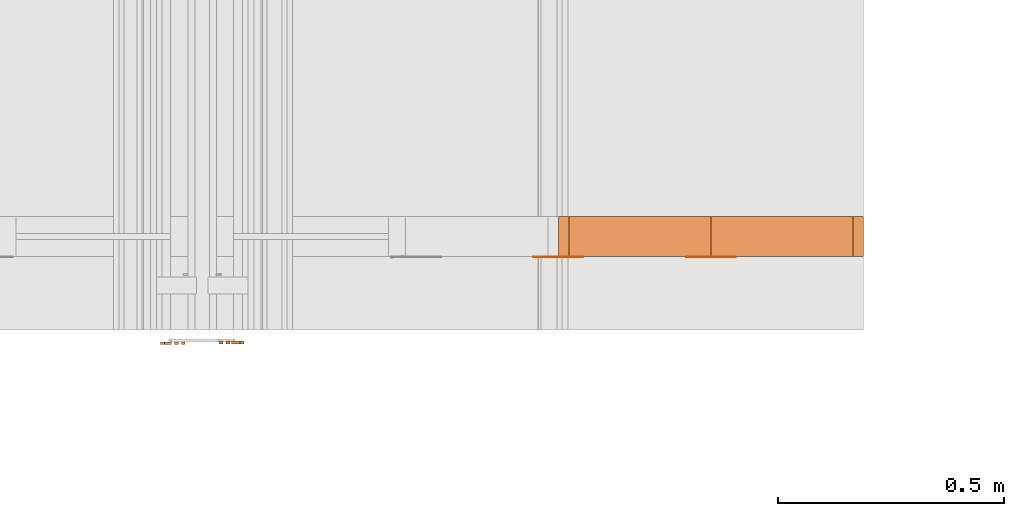
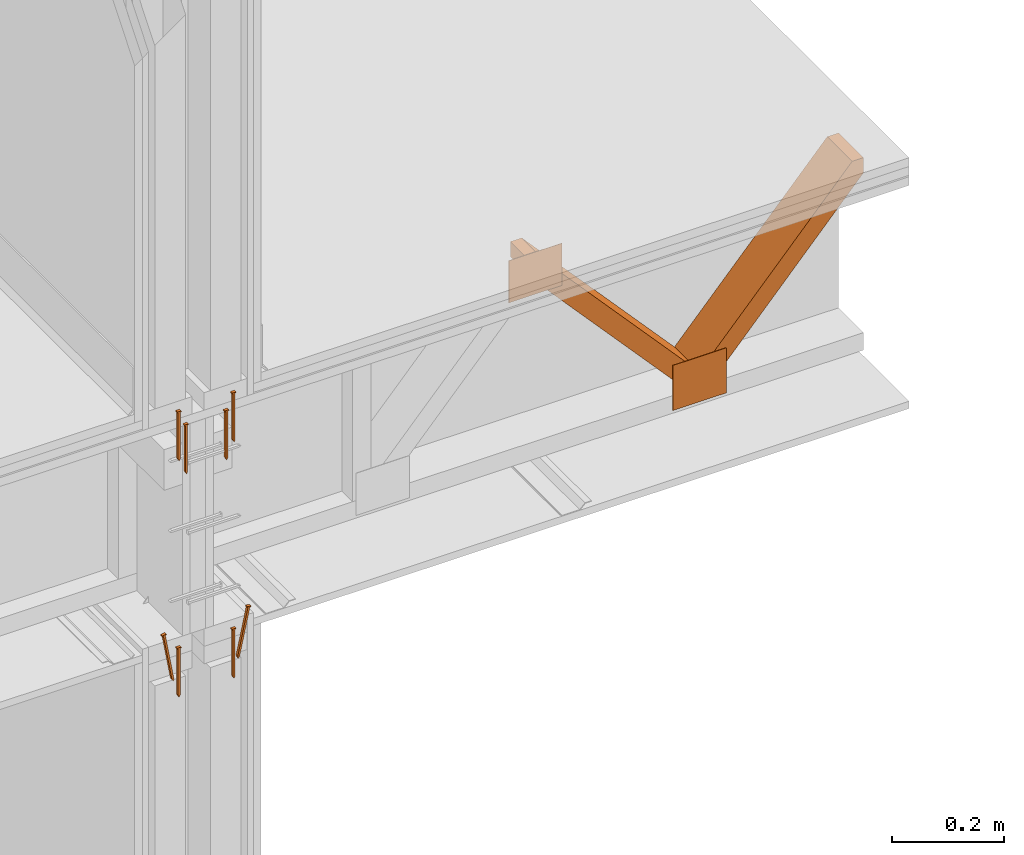
# One storey, part 7 of 22: 12 proxies.
"""IFC2X3 building model written with IfcOpenShell, lengths in feet."""

from ifc_helpers import new_model, entity, si_unit, converted_unit, frame, frame_2d, origin_with_axes, place, context, subcontext, project, spatial, polyline, rectangle, outline, extrude, source, transform, mapped, type_object, type_shapes, element, save


model = new_model("IFC2X3")

# Units and contexts
model_context = context("Model", 3, precision=1e-05)
plan_context = context("Plan", 2, precision=1e-05, world=frame_2d((0.0, 0.0, 0.0), x_axis=(1.0, 0.0, 0.0)))
body_context = subcontext(model_context, "Body", "Model", "MODEL_VIEW")
ifc_project = project(units=[converted_unit("VOLUMEUNIT", "cubic foot", entity("IfcReal", 0.0283168467116885), si_unit("VOLUMEUNIT", "CUBIC_METRE"), dimensions=[3, 0, 0, 0, 0, 0, 0]), converted_unit("AREAUNIT", "square foot", entity("IfcReal", 0.09290304), si_unit("AREAUNIT", "SQUARE_METRE"), dimensions=[2, 0, 0, 0, 0, 0, 0]), converted_unit("LENGTHUNIT", "foot", entity("IfcReal", 0.3048), si_unit("LENGTHUNIT", "METRE"), dimensions=[1, 0, 0, 0, 0, 0, 0])], contexts=[model_context, plan_context])

# Site, building, storey
site_placement = place(None, origin_with_axes())
site = spatial("IfcSite", under=ifc_project, at=site_placement, CompositionType="ELEMENT")
building_placement = place(site_placement, origin_with_axes())
building = spatial("IfcBuilding", under=site, at=building_placement, Name="Building", CompositionType="ELEMENT")
storey_placement = place(building_placement, origin_with_axes())
storey = spatial("IfcBuildingStorey", under=building, at=storey_placement, Name="Storey", CompositionType="ELEMENT")

# Proxies
building_element_proxy_type_1 = type_object("IfcBuildingElementProxyType", PredefinedType="NOTDEFINED")
shared_shape_1 = source(origin_with_axes(), body_context, "Body", "SweptSolid", [
    extrude(outline(polyline([(0.111323627313291, -4.3989495809459e-10), (0.11174819796417, -0.00686187809210984), (0.11861007758404, -0.00643729980243003), (0.11691175831428, 0.0210102125660093), (0.110049890916491, 0.0205856327485694), (0.110474473789452, 0.0137237546564596), (-0.222222659531541, -0.00686187580046965), (-0.235521848120402, -0.0145729081802989), (-0.22137349378562, -0.0205856312208093), (0.111323627313291, -4.3989495809459e-10)])), frame((0.111111134212474, 9.54850080601499e-11, -0.0200000086804153), z_axis=(-5.63213937709861e-08, 0.0, -1.0), x_axis=(-0.998091220855713, -0.0617568753659725, 6.86179575382084e-08)), (-2.94874541451051e-10, 4.76513584146687e-09, -0.999999940395355), 0.0199999997321788),
])
type_shapes(building_element_proxy_type_1, [shared_shape_1])
for number, where, z_axis, x_axis in (
    (1, (1575.65519878558, 1.80479774637798, -59.9519161414599), (-1.62920684942947e-07, 1.0, -1.23001694617955e-14), (7.54979012640433e-08, 0.0, -1.0)),
    (2, (1576.03016049843, 1.81167261806999, -59.9519161414599), (-1.62920684942947e-07, 1.0, -1.23001694617955e-14), (7.54979012640433e-08, 0.0, -1.0)),
    (3, (1575.65519878558, 1.80479774637798, -61.6394190650599), (-1.62920684942947e-07, 1.0, -1.23001694617955e-14), (7.54979012640433e-08, 0.0, -1.0)),
    (4, (1576.03016049843, 1.81167261806999, -61.6394190650599), (-1.62920684942947e-07, 1.0, -1.23001694617955e-14), (7.54979012640433e-08, 0.0, -1.0)),
):
    element("IfcBuildingElementProxy", number, at=place(storey_placement, frame(where, z_axis=z_axis, x_axis=x_axis)), inside=storey, type_object=building_element_proxy_type_1, context=body_context, shape_type="MappedRepresentation", body=[
        mapped(shared_shape_1, transform((0.0, 0.0, 0.0), x_axis=(1.0, 0.0, 0.0), y_axis=(0.0, 1.0, 0.0), z_axis=(0.0, 0.0, 1.0), scale=1.0)),
    ])
building_element_proxy_type_2 = type_object("IfcBuildingElementProxyType", PredefinedType="NOTDEFINED")
shared_shape_2 = source(origin_with_axes(), body_context, "Body", "SweptSolid", [
    extrude(outline(polyline([(-0.111111109768312, -0.0068750000238575), (0.222222243980786, -0.0068750000238575), (0.23597223180642, -2.15302076254909e-09), (0.222222268424948, 0.0068750023154977), (-0.111111121990393, 0.00687499925997744), (-0.111111109768312, 0.013750000047715), (-0.11798611590321, 0.013750000047715), (-0.11798611590321, -0.013750000047715), (-0.111111121990393, -0.0137500015754751), (-0.111111109768312, -0.0068750000238575)])), frame((0.111111109768312, 0.0, -0.020000005624895), z_axis=(-6.61350867403598e-08, -6.13854399169472e-14, -1.0), x_axis=(1.0, -2.29163998888282e-09, -6.87492018869307e-08)), (2.04888596323435e-14, 6.14665585682399e-14, -0.999999940395355), 0.0199999997321788),
])
type_shapes(building_element_proxy_type_2, [shared_shape_2])
for number, where, z_axis, x_axis in (
    (5, (1575.55517562105, 1.80479774637798, -61.5144213979326), (-1.19624363748017e-08, 0.999999940395355, -2.82908843018959e-08), (0.173648223280907, -2.5783826629322e-08, -0.984807729721069)),
    (6, (1576.13018366296, 1.81167261806999, -61.5144213979326), (-1.66480887742182e-07, 1.0, -3.38731069859932e-08), (-0.207911655306816, -6.77462139719864e-08, -0.978147625923157)),
):
    element("IfcBuildingElementProxy", number, at=place(storey_placement, frame(where, z_axis=z_axis, x_axis=x_axis)), inside=storey, type_object=building_element_proxy_type_2, context=body_context, shape_type="MappedRepresentation", body=[
        mapped(shared_shape_2, transform((0.0, 0.0, 0.0), x_axis=(1.0, 0.0, 0.0), y_axis=(0.0, 1.0, 0.0), z_axis=(0.0, 0.0, 1.0), scale=1.0)),
    ])
building_element_proxy_type_3 = type_object("IfcBuildingElementProxyType", Name="SUBFLOOR TO RIBBON BOARD", PredefinedType="NOTDEFINED")
shared_shape_3 = source(origin_with_axes(), body_context, "Body", "SweptSolid", [
    extrude(outline(polyline([(-0.222222268424948, -0.00687499849609737), (0.111111109768312, -0.00687499849609737), (0.111111109768312, -0.013750000047715), (0.117986103681129, -0.013750000047715), (0.117986103681129, 0.0137500031032353), (0.111111109768312, 0.0137500015754751), (0.111111109768312, 0.00687499925997744), (-0.222222243980786, 0.00687499925997744), (-0.23597223180642, -3.87233552310243e-09), (-0.222222268424948, -0.00687499849609737)])), frame((0.111111109768312, 1.11521265392398e-09, -0.020000005624895), z_axis=(-7.04017537600521e-08, -6.90586436234882e-14, -1.0), x_axis=(-1.0, -6.87492018869307e-09, 6.87492018869307e-08)), (-1.70740496936196e-14, 3.81939351257188e-08, -1.0), 0.0200000007111508),
])
type_shapes(building_element_proxy_type_3, [shared_shape_3])
for number, where, z_axis, x_axis in (
    (7, (1575.70516030619, 1.80479774637798, -60.061914088532), (-1.62920684942947e-07, 1.0, -1.23001694617955e-14), (7.54979012640433e-08, 0.0, -1.0)),
    (8, (1575.98019897781, 1.81167261806999, -60.061914088532), (-1.62920684942947e-07, 1.0, -1.23001694617955e-14), (7.54979012640433e-08, 0.0, -1.0)),
):
    element("IfcBuildingElementProxy", number, at=place(storey_placement, frame(where, z_axis=z_axis, x_axis=x_axis)), inside=storey, type_object=building_element_proxy_type_3, context=body_context, shape_type="MappedRepresentation", body=[
        mapped(shared_shape_3, transform((0.0, 0.0, 0.0), x_axis=(1.0, 0.0, 0.0), y_axis=(0.0, 1.0, 0.0), z_axis=(0.0, 0.0, 1.0), scale=1.0)),
    ])
proxy_1_placement = place(storey_placement, frame((1580.64784653231, 2.42488140978525, -60.2675360331698), z_axis=(0.0, 0.0, 1.0), x_axis=(1.0, 0.0, 0.0)))
element("IfcBuildingElementProxy", 9, at=proxy_1_placement, inside=storey, Name="Generic Models 855:Generic Models 1", context=body_context, shape_type="SweptSolid", body=[
    extrude(outline(polyline([(-0.624998944403305, -0.554331018542993), (-0.516033714290053, -0.554331018542993), (0.624998846626657, 0.478032379951377), (0.624998846626657, 0.554331018542993), (0.516033420960108, 0.554331018542993), (-0.624998944403305, -0.478032379951377), (-0.624998944403305, -0.554331018542993)])), frame((-0.554349009446272, 5.04959154105692e-08, -0.625001095489567), z_axis=(-7.55358386950178e-10, 1.0, -1.20567129613391e-08), x_axis=(0.0, -1.15278186996193e-08, -1.0)), (-1.15278204759761e-08, -7.5535849797248e-10, 1.0), 0.291666664589754),
])
proxy_2_placement = place(storey_placement, frame((1578.43051620043, 2.42488140978525, -60.2675360331698), z_axis=(0.0, 0.0, 1.0), x_axis=(1.0, 0.0, 0.0)))
element("IfcBuildingElementProxy", 10, at=proxy_2_placement, inside=storey, Name="Generic Models 855:Generic Models 1", context=body_context, shape_type="SweptSolid", body=[
    extrude(outline(polyline([(-0.784177274450542, -0.0648422648255124), (0.754565469861969, -0.0648421976040667), (0.835367114212256, 0.00826413119871785), (0.784177323338866, 0.0648422464923909), (-0.754565372085321, 0.0648422037151073), (-0.835367016435608, -0.00826411286559631), (-0.784177274450542, -0.0648422648255124)])), frame((0.554370911415481, 2.60517416912861e-08, -0.625000459941353), z_axis=(-5.6313624874349e-09, 1.0, 3.61700465134618e-08), x_axis=(0.670913577079773, 3.07118845910281e-08, -0.741535544395447)), (1.14520453564637e-07, 2.00911216552413e-08, 1.0), 0.291666664589756),
])
proxy_3_placement = place(storey_placement, frame((1579.35865907844, 2.42211120178693, -61.6217035008228), z_axis=(0.0, 0.0, 1.0), x_axis=(1.0, 0.0, 0.0)))
element("IfcBuildingElementProxy", 11, at=proxy_3_placement, inside=storey, Name="Generic Models 852:Generic Models 1", context=body_context, shape_type="SweptSolid", body=[
    extrude(rectangle(XDim=0.360930148950862, YDim=0.00277022707595213, at=frame_2d((0.0, 0.0, 0.0))), frame((0.180465076363149, 0.00138511354766121, 0.0), z_axis=(0.0, 0.0, -1.0), x_axis=(-1.0, 0.0, 0.0)), (0.0, 0.0, -1.0), 0.322097519461289),
])
proxy_4_placement = place(storey_placement, frame((1577.14132874657, 2.42211120178693, -61.9550389567698), z_axis=(0.0, 0.0, 1.0), x_axis=(1.0, 0.0, 0.0)))
element("IfcBuildingElementProxy", 12, at=proxy_4_placement, inside=storey, Name="Generic Models 852:Generic Models 1", context=body_context, shape_type="SweptSolid", body=[
    extrude(rectangle(XDim=0.360930176725411, YDim=0.00277022707595213, at=frame_2d((0.0, 0.0, 0.0))), frame((1.28912702789457, 0.00138511354766121, 1.4904025071875), z_axis=(0.0, 0.0, -1.0), x_axis=(1.0, 0.0, 0.0)), (0.0, 0.0, -1.0), 0.301264218204712),
])

save(model, "model.ifc")
